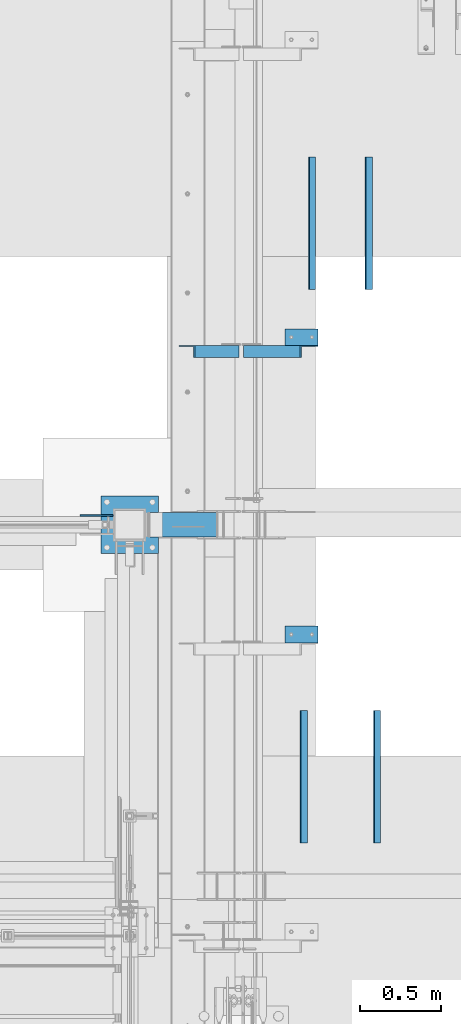
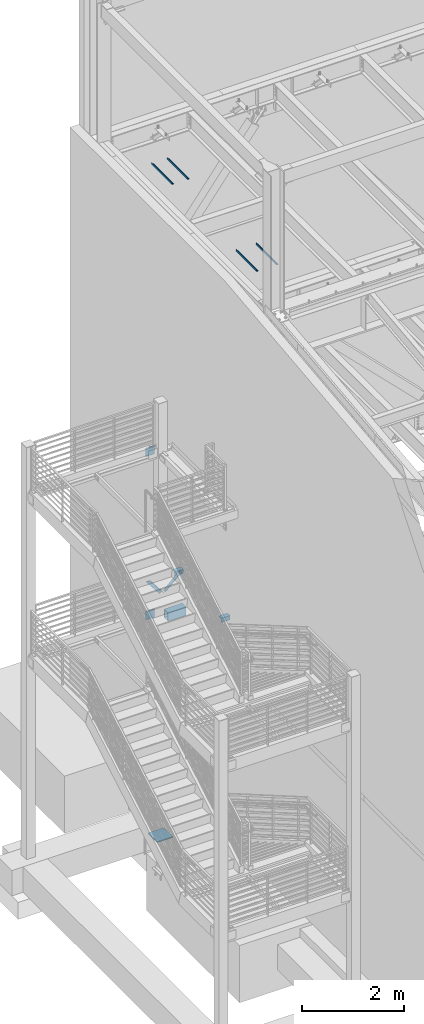
# One storey, part 879 of 1179: 10 beams, 2 members, 10 elements without a shape of their own.
"""IFC2X3 building model written with IfcOpenShell, lengths in millimetres."""

from ifc_helpers import new_model, si_unit, frame, origin_with_axes, place, context, subcontext, project, spatial, faceted_brep, material, type_object, element, aggregate, save


model = new_model("IFC2X3")

# Units and contexts
model_context = context("Model", 3, precision=1e-05, world=origin_with_axes())
body_context = subcontext(model_context, "Body", "Model", "MODEL_VIEW")
ifc_project = project(units=[si_unit("LENGTHUNIT", "METRE", prefix="MILLI"), si_unit("AREAUNIT", "SQUARE_METRE"), si_unit("VOLUMEUNIT", "CUBIC_METRE"), si_unit("MASSUNIT", "GRAM", prefix="KILO"), si_unit("TIMEUNIT", "SECOND"), si_unit("PLANEANGLEUNIT", "RADIAN"), si_unit("SOLIDANGLEUNIT", "STERADIAN"), si_unit("THERMODYNAMICTEMPERATUREUNIT", "DEGREE_CELSIUS"), si_unit("LUMINOUSINTENSITYUNIT", "LUMEN")], contexts=[model_context])

# Site, building, storey
site_placement = place(None, origin_with_axes())
site = spatial("IfcSite", under=ifc_project, at=site_placement, CompositionType="ELEMENT")
building_placement = place(site_placement, origin_with_axes())
building = spatial("IfcBuilding", under=site, at=building_placement, Name="Undefined", CompositionType="ELEMENT")
storey_placement = place(building_placement, origin_with_axes())
storey = spatial("IfcBuildingStorey", under=building, at=storey_placement, Name="Undefined", CompositionType="ELEMENT", Elevation=0.0)

# Assembly, member
assembly_1_placement = place(storey_placement, origin_with_axes())
assembly_1 = element("IfcElementAssembly", 1, at=assembly_1_placement, inside=storey, Name="ANGLE", AssemblyPlace="NOTDEFINED", PredefinedType="RIGID_FRAME")
ifc_material_1 = material(Name="STEEL/A36")
member_type = type_object("IfcMemberType", Name="L3X3X1/4", PredefinedType="NOTDEFINED")
member_1_placement = place(assembly_1_placement, frame((472.414639168561, 38708.0125, 3736.19330123132), z_axis=(0.0, -1.0, 0.0), x_axis=(0.729484494811633, 0.0, 0.683997347823379)))
member_1 = element("IfcMember", 2, at=member_1_placement, type_object=member_type, material=ifc_material_1, Name="ANGLE", ObjectType="L3X3X1/4", context=body_context, shape_type="Brep", body=[
    faceted_brep([(0.0, 38.0999999999985, -38.0999999999999), (0.0, 38.0999999999985, 38.0999999999999), (475.752341075195, 38.0999999999181, 38.1000000000004), (475.752341075195, 38.0999999999181, -38.1000000000004), (0.0, 31.75, 38.1000000000004), (482.524628360803, 31.7499999999177, 38.1000000000004), (0.0, 31.75, -31.75), (482.524628360803, 31.7499999999177, -31.75), (0.0, -38.0999999999985, -31.75), (557.019788502486, -38.1000000000854, -31.75), (0.0, -38.0999999999985, -38.0999999999999), (557.019788502486, -38.1000000000854, -38.1000000000004)], [[[0, 1, 2, 3]], [[1, 4, 5, 2]], [[4, 6, 7, 5]], [[6, 8, 9, 7]], [[8, 10, 11, 9]], [[10, 0, 3, 11]], [[5, 7, 9, 11, 3, 2]], [[10, 8, 6, 4, 1, 0]]]),
])
aggregate(assembly_1, [member_1])

assembly_2_placement = place(storey_placement, origin_with_axes())
assembly_2 = element("IfcElementAssembly", 3, at=assembly_2_placement, inside=storey, Name="ANGLE", AssemblyPlace="NOTDEFINED", PredefinedType="RIGID_FRAME")
member_2_placement = place(assembly_2_placement, frame((80.8196258456446, 38708.0125, 4125.56128839178), z_axis=(0.0, -1.0, 0.0), x_axis=(0.614083067285056, 0.0, -0.789241399366364)))
member_2 = element("IfcMember", 4, at=member_2_placement, type_object=member_type, material=ifc_material_1, Name="ANGLE", ObjectType="L3X3X1/4", context=body_context, shape_type="Brep", body=[
    faceted_brep([(59.3707492954454, 38.0999999999781, -38.1000000000004), (59.3707492954454, 38.0999999999781, 38.1000000000004), (499.083854779058, 38.0999999998585, 38.1000000000004), (499.083854779058, 38.0999999998585, -38.1000000000004), (54.4300207928691, 31.7499999999804, 38.1000000000004), (499.083854779056, 31.7499999998595, 38.1000000000004), (54.4300207928691, 31.7499999999804, -31.75), (499.083854779056, 31.7499999998595, -31.75), (0.0820072645328764, -38.0999999999945, -31.75), (499.083854779043, -38.10000000013, -31.75), (0.0820072645328764, -38.0999999999945, -38.1000000000004), (499.083854779043, -38.10000000013, -38.1000000000004)], [[[0, 1, 2, 3]], [[1, 4, 5, 2]], [[4, 6, 7, 5]], [[6, 8, 9, 7]], [[8, 10, 11, 9]], [[10, 0, 3, 11]], [[5, 7, 9, 11, 3, 2]], [[10, 8, 6, 4, 1, 0]]]),
])
aggregate(assembly_2, [member_2])

# Assembly, beam
assembly_3_placement = place(storey_placement, origin_with_axes())
assembly_3 = element("IfcElementAssembly", 5, at=assembly_3_placement, inside=storey, Name="ANGLE", AssemblyPlace="NOTDEFINED", PredefinedType="RIGID_FRAME")
beam_type_1 = type_object("IfcBeamType", Name="L4X4X1/4", PredefinedType="NOTDEFINED")
beam_1_placement = place(assembly_3_placement, frame((701.59635534156, 38796.9125, 4051.3), z_axis=(0.0, 0.0, -1.0), x_axis=(1.0, 0.0, 0.0)))
beam_1 = element("IfcBeam", 6, at=beam_1_placement, type_object=beam_type_1, material=ifc_material_1, Name="ANGLE", ObjectType="L4X4X1/4", context=body_context, shape_type="Brep", body=[
    faceted_brep([(1.90993887372315e-11, 50.8000000000002, -50.8000000000002), (1.90993887372315e-11, 50.8000000000002, 50.8000000000002), (203.200000000001, 50.7999999999993, 50.8000000000002), (203.200000000001, 50.7999999999993, -50.8000000000002), (0.0, 44.4500000000007, 50.8000000000002), (203.200000000001, 44.4500000000007, 50.8000000000002), (0.0, 44.4500000000007, -44.4499999999998), (203.200000000001, 44.4500000000007, -44.4499999999998), (0.0, -50.7999999999993, -44.4499999999998), (203.200000000001, -50.7999999999993, -44.4499999999998), (-1.81898940354586e-11, -50.7999999999997, -50.8000000000002), (203.200000000001, -50.7999999999993, -50.8000000000002)], [[[0, 1, 2, 3]], [[1, 4, 5, 2]], [[4, 6, 7, 5]], [[6, 8, 9, 7]], [[8, 10, 11, 9]], [[10, 0, 3, 11]], [[5, 7, 9, 11, 3, 2]], [[10, 8, 6, 4, 1, 0]]]),
])
aggregate(assembly_3, [beam_1])

assembly_4_placement = place(storey_placement, origin_with_axes())
assembly_4 = element("IfcElementAssembly", 7, at=assembly_4_placement, inside=storey, Name="ANGLE", AssemblyPlace="NOTDEFINED", PredefinedType="RIGID_FRAME")
beam_2_placement = place(assembly_4_placement, frame((701.59635534156, 36968.1125, 4051.3), z_axis=(0.0, 0.0, -1.0), x_axis=(1.0, 0.0, 0.0)))
beam_2 = element("IfcBeam", 8, at=beam_2_placement, type_object=beam_type_1, material=ifc_material_1, Name="ANGLE", ObjectType="L4X4X1/4", context=body_context, shape_type="Brep", body=[
    faceted_brep([(1.90993887372315e-11, 50.8000000000002, -50.8000000000002), (1.90993887372315e-11, 50.8000000000002, 50.8000000000002), (203.200000000001, 50.7999999999993, 50.8000000000002), (203.200000000001, 50.7999999999993, -50.8000000000002), (0.0, 44.4500000000007, 50.8000000000002), (203.200000000001, 44.4500000000007, 50.8000000000002), (0.0, 44.4500000000007, -44.4499999999998), (203.200000000001, 44.4500000000007, -44.4499999999998), (0.0, -50.7999999999993, -44.4499999999998), (203.200000000001, -50.7999999999993, -44.4499999999998), (-1.81898940354586e-11, -50.7999999999997, -50.8000000000002), (203.200000000001, -50.7999999999993, -50.8000000000002)], [[[0, 1, 2, 3]], [[1, 4, 5, 2]], [[4, 6, 7, 5]], [[6, 8, 9, 7]], [[8, 10, 11, 9]], [[10, 0, 3, 11]], [[5, 7, 9, 11, 3, 2]], [[10, 8, 6, 4, 1, 0]]]),
])
aggregate(assembly_4, [beam_2])

# Assembly, beams
assembly_5_placement = place(storey_placement, origin_with_axes())
assembly_5 = element("IfcElementAssembly", 9, at=assembly_5_placement, inside=storey, Name="COLUMN", AssemblyPlace="NOTDEFINED", PredefinedType="RIGID_FRAME")
beam_type_2 = type_object("IfcBeamType", PredefinedType="NOTDEFINED")
beam_3_placement = place(assembly_5_placement, frame((-558.8, 37699.95, 8045.45), z_axis=(0.0, 0.0, 1.0), x_axis=(1.0, 0.0, 0.0)))
beam_3 = element("IfcBeam", 10, at=beam_3_placement, type_object=beam_type_2, material=ifc_material_1, Name="PLATE", context=body_context, shape_type="Brep", body=[
    faceted_brep([(0.0, 4.76250000000073, -101.6), (0.0, 4.76250000000073, 101.6), (203.199999999997, 4.76250000000073, 101.6), (203.199999999997, 4.76250000000073, -101.6), (0.0, -4.76250000000073, 101.6), (203.199999999997, -4.76250000000073, 101.6), (0.0, -4.76250000000073, -101.6), (203.199999999997, -4.76250000000073, -101.6)], [[[0, 1, 2, 3]], [[1, 4, 5, 2]], [[4, 6, 7, 5]], [[6, 0, 3, 7]], [[5, 7, 3, 2]], [[6, 4, 1, 0]]]),
])
beam_4_placement = place(assembly_5_placement, frame((-558.8, 37699.95, 4133.85), z_axis=(0.0, 0.0, 1.0), x_axis=(1.0, 0.0, 0.0)))
beam_4 = element("IfcBeam", 11, at=beam_4_placement, type_object=beam_type_2, material=ifc_material_1, Name="PLATE", context=body_context, shape_type="Brep", body=[
    faceted_brep([(0.0, 4.76250000000073, -101.6), (0.0, 4.76250000000073, 101.6), (203.199999999997, 4.76250000000073, 101.6), (203.199999999997, 4.76250000000073, -101.6), (0.0, -4.76250000000073, 101.6), (203.199999999997, -4.76250000000073, 101.6), (0.0, -4.76250000000073, -101.6), (203.199999999997, -4.76250000000073, -101.6)], [[[0, 1, 2, 3]], [[1, 4, 5, 2]], [[4, 6, 7, 5]], [[6, 0, 3, 7]], [[5, 7, 3, 2]], [[6, 4, 1, 0]]]),
])

# Assembly, beam
assembly_6_placement = place(storey_placement, origin_with_axes())
assembly_6 = element("IfcElementAssembly", 12, at=assembly_6_placement, inside=storey, Name="ANGLE", AssemblyPlace="NOTDEFINED", PredefinedType="RIGID_FRAME")
ifc_material_2 = material(Name="STEEL/A992")
beam_type_3 = type_object("IfcBeamType", Name="L1-3/4X1-3/4X1/4", PredefinedType="NOTDEFINED")
beam_5_placement = place(assembly_6_placement, frame((1266.82500038, 35687.0, 13141.32500038), z_axis=(0.0, 0.0, 1.0), x_axis=(0.0, 1.0, 0.0)))
beam_5 = element("IfcBeam", 13, at=beam_5_placement, type_object=beam_type_3, material=ifc_material_2, Name="ANGLE", ObjectType="L1-3/4X1-3/4X1/4", context=body_context, shape_type="Brep", body=[
    faceted_brep([(0.0, 22.22500038, -22.22500038), (0.0, 22.22500038, 22.22500038), (812.800000000003, 22.22500038, 22.22500038), (812.800000000003, 22.22500038, -22.22500038), (-2.3032567586398e-12, 15.8749999523186, 22.2250003814697), (812.800000000003, 15.875000475, 22.22500038), (0.0, 15.8749992830017, -15.8749992829999), (812.800000000003, 15.875000475, -15.875000475), (0.0, -22.22500038, -15.875000475), (812.800000000003, -22.22500038, -15.875000475), (0.0, -22.22500038, -22.22500038), (812.800000000003, -22.22500038, -22.22500038)], [[[0, 1, 2, 3]], [[1, 4, 5, 2]], [[4, 6, 7, 5]], [[6, 8, 9, 7]], [[8, 10, 11, 9]], [[10, 0, 3, 11]], [[5, 7, 9, 11, 3, 2]], [[10, 8, 6, 4, 1, 0]]]),
])
aggregate(assembly_6, [beam_5])

assembly_7_placement = place(storey_placement, origin_with_axes())
assembly_7 = element("IfcElementAssembly", 14, at=assembly_7_placement, inside=storey, Name="ANGLE", AssemblyPlace="NOTDEFINED", PredefinedType="RIGID_FRAME")
beam_6_placement = place(assembly_7_placement, frame((815.97499962, 35687.0, 13141.32500038), z_axis=(0.0, 0.0, 1.0), x_axis=(0.0, 1.0, 0.0)))
beam_6 = element("IfcBeam", 15, at=beam_6_placement, type_object=beam_type_3, material=ifc_material_2, Name="ANGLE", ObjectType="L1-3/4X1-3/4X1/4", context=body_context, shape_type="Brep", body=[
    faceted_brep([(0.0, 22.22500038, -22.22500038), (0.0, 22.22500038, 22.22500038), (812.800000000003, 22.22500038, 22.22500038), (812.800000000003, 22.22500038, -22.22500038), (-2.3032567586398e-12, 15.8749999523186, 22.2250003814697), (812.800000000003, 15.875000475, 22.22500038), (0.0, 15.8749992830017, -15.8749992829999), (812.800000000003, 15.875000475, -15.875000475), (0.0, -22.22500038, -15.875000475), (812.800000000003, -22.22500038, -15.875000475), (0.0, -22.22500038, -22.22500038), (812.800000000003, -22.22500038, -22.22500038)], [[[0, 1, 2, 3]], [[1, 4, 5, 2]], [[4, 6, 7, 5]], [[6, 8, 9, 7]], [[8, 10, 11, 9]], [[10, 0, 3, 11]], [[5, 7, 9, 11, 3, 2]], [[10, 8, 6, 4, 1, 0]]]),
])
aggregate(assembly_7, [beam_6])

assembly_8_placement = place(storey_placement, origin_with_axes())
assembly_8 = element("IfcElementAssembly", 16, at=assembly_8_placement, inside=storey, Name="ANGLE", AssemblyPlace="NOTDEFINED", PredefinedType="RIGID_FRAME")
beam_7_placement = place(assembly_8_placement, frame((1216.02500038, 39090.6, 13141.32500038), z_axis=(0.0, 0.0, 1.0), x_axis=(0.0, 1.0, 0.0)))
beam_7 = element("IfcBeam", 17, at=beam_7_placement, type_object=beam_type_3, material=ifc_material_2, Name="ANGLE", ObjectType="L1-3/4X1-3/4X1/4", context=body_context, shape_type="Brep", body=[
    faceted_brep([(0.0, 22.22500038, -22.22500038), (0.0, 22.22500038, 22.22500038), (812.800000000003, 22.22500038, 22.22500038), (812.800000000003, 22.22500038, -22.22500038), (-2.3032567586398e-12, 15.8749999523186, 22.2250003814697), (812.800000000003, 15.875000475, 22.22500038), (0.0, 15.8749992830017, -15.8749992829999), (812.800000000003, 15.875000475, -15.875000475), (0.0, -22.22500038, -15.875000475), (812.800000000003, -22.22500038, -15.875000475), (0.0, -22.22500038, -22.22500038), (812.800000000003, -22.22500038, -22.22500038)], [[[0, 1, 2, 3]], [[1, 4, 5, 2]], [[4, 6, 7, 5]], [[6, 8, 9, 7]], [[8, 10, 11, 9]], [[10, 0, 3, 11]], [[5, 7, 9, 11, 3, 2]], [[10, 8, 6, 4, 1, 0]]]),
])
aggregate(assembly_8, [beam_7])

assembly_9_placement = place(storey_placement, origin_with_axes())
assembly_9 = element("IfcElementAssembly", 18, at=assembly_9_placement, inside=storey, Name="ANGLE", AssemblyPlace="NOTDEFINED", PredefinedType="RIGID_FRAME")
beam_8_placement = place(assembly_9_placement, frame((866.77499962, 39090.6, 13141.32500038), z_axis=(0.0, 0.0, 1.0), x_axis=(0.0, 1.0, 0.0)))
beam_8 = element("IfcBeam", 19, at=beam_8_placement, type_object=beam_type_3, material=ifc_material_2, Name="ANGLE", ObjectType="L1-3/4X1-3/4X1/4", context=body_context, shape_type="Brep", body=[
    faceted_brep([(0.0, 22.22500038, -22.22500038), (0.0, 22.22500038, 22.22500038), (812.800000000003, 22.22500038, 22.22500038), (812.800000000003, 22.22500038, -22.22500038), (-2.3032567586398e-12, 15.8749999523186, 22.2250003814697), (812.800000000003, 15.875000475, 22.22500038), (0.0, 15.8749992830017, -15.8749992829999), (812.800000000003, 15.875000475, -15.875000475), (0.0, -22.22500038, -15.875000475), (812.800000000003, -22.22500038, -15.875000475), (0.0, -22.22500038, -22.22500038), (812.800000000003, -22.22500038, -22.22500038)], [[[0, 1, 2, 3]], [[1, 4, 5, 2]], [[4, 6, 7, 5]], [[6, 8, 9, 7]], [[8, 10, 11, 9]], [[10, 0, 3, 11]], [[5, 7, 9, 11, 3, 2]], [[10, 8, 6, 4, 1, 0]]]),
])
aggregate(assembly_9, [beam_8])

assembly_10_placement = place(storey_placement, origin_with_axes())
assembly_10 = element("IfcElementAssembly", 20, at=assembly_10_placement, inside=storey, Name="BEAM", AssemblyPlace="NOTDEFINED", PredefinedType="RIGID_FRAME")
ifc_material_3 = material()
beam_type_4 = type_object("IfcBeamType", Name="HSS8X6X3/8", PredefinedType="NOTDEFINED")
beam_9_placement = place(assembly_10_placement, frame((-139.700000000002, 37642.8, 4032.25), z_axis=(0.0, 0.0, 1.0), x_axis=(1.0, 0.0, 0.0)))
beam_9 = element("IfcBeam", 21, at=beam_9_placement, type_object=beam_type_4, material=ifc_material_3, Name="BEAM", ObjectType="HSS8X6X3/8", context=body_context, shape_type="Brep", body=[
    faceted_brep([(9.52500000002851, 66.6750000000029, -92.0750000000025), (9.52500000002851, -66.6750000000029, -92.0750000000025), (419.099952093158, -66.6750000014945, -92.0749999999998), (419.099952092685, 66.6749999985113, -92.0749999999998), (9.52499999997079, -66.6750000000029, 92.074999999998), (419.099952093158, -66.6750000014945, 92.0750000000003), (9.52499999997079, 66.6750000000029, 92.074999999998), (419.099952092685, 66.6749999985113, 92.0750000000003), (9.52500000003153, 76.1999999999971, -101.600000000002), (9.52499999996778, 76.1999999999971, 101.599999999998), (419.099952092651, 76.1999999985055, 101.6), (419.099952092651, 76.1999999985055, -101.6), (9.52499999996778, -76.1999999999971, 101.599999999998), (419.099952093192, -76.2000000014887, 101.6), (9.52500000003153, -76.1999999999971, -101.600000000002), (419.099952093192, -76.2000000014887, -101.6)], [[[0, 1, 2, 3]], [[1, 4, 5, 2]], [[4, 6, 7, 5]], [[6, 0, 3, 7]], [[8, 9, 10, 11]], [[9, 12, 13, 10]], [[12, 14, 15, 13]], [[14, 8, 11, 15]], [[13, 15, 11, 10], [5, 7, 3, 2]], [[14, 12, 9, 8], [6, 4, 1, 0]]]),
])
aggregate(assembly_10, [beam_9])

# Beam
ifc_material_4 = material(Name="STEEL/A572-GR.50")
beam_type_5 = type_object("IfcBeamType", PredefinedType="NOTDEFINED")
beam_10_placement = place(assembly_5_placement, frame((-254.0, 37465.0000030518, -1193.8), z_axis=(-1.0, 0.0, 0.0), x_axis=(0.0, 1.0, 0.0)))
beam_10 = element("IfcBeam", 22, at=beam_10_placement, type_object=beam_type_5, material=ifc_material_4, context=body_context, shape_type="Brep", body=[
    faceted_brep([(0.0, 12.7, -177.8), (9.50323374127038e-06, 12.7000000000007, 177.80000656152), (355.599999999999, 12.7, 177.8), (355.599999999999, 12.7, -177.8), (9.50323374127038e-06, -12.7000000000007, 177.80000656152), (355.599999999999, -12.7, 177.8), (0.0, -12.7, -177.8), (355.599999999999, -12.7, -177.8)], [[[0, 1, 2, 3]], [[1, 4, 5, 2]], [[4, 6, 7, 5]], [[6, 0, 3, 7]], [[5, 7, 3, 2]], [[6, 4, 1, 0]]]),
])

aggregate(assembly_5, [beam_3, beam_4, beam_10])

save(model, "model.ifc")
